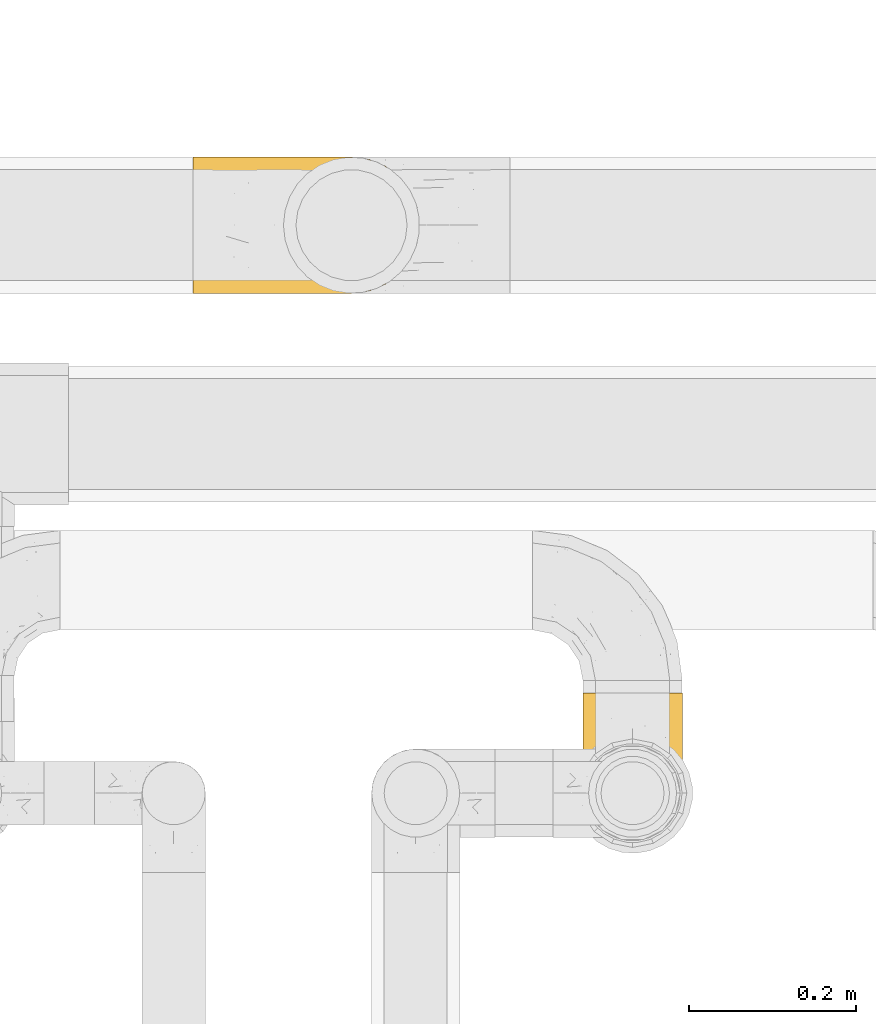
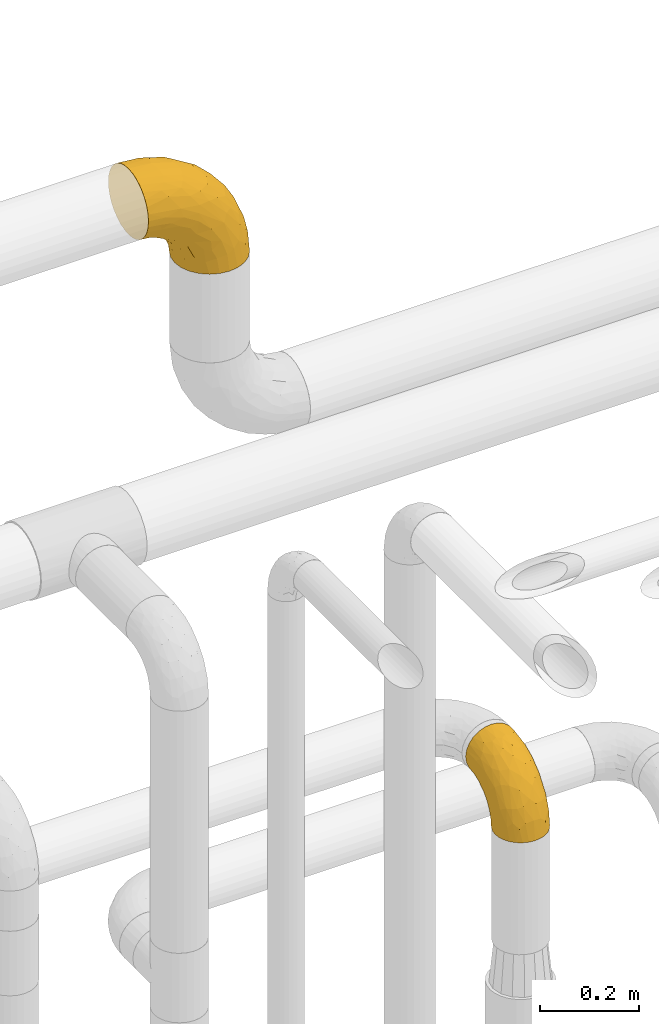
# One storey, part 475 of 827: 2 coverings.
"""IFC2X3 building model written with IfcOpenShell, lengths in millimetres."""

from ifc_helpers import new_model, entity, si_unit, converted_unit, derived_unit, direction, frame, origin, place, context, subcontext, project, spatial, faceted_brep, element, save


model = new_model("IFC2X3")

# Units and contexts
model_context = context("Model", 3, precision=0.01, world=origin(), true_north=direction((6.12303176911189e-17, 1.0)))
body_context = subcontext(model_context, "Body", "Model", "MODEL_VIEW")
ifc_project = project(units=[si_unit("LENGTHUNIT", "METRE", prefix="MILLI"), si_unit("AREAUNIT", "SQUARE_METRE"), si_unit("VOLUMEUNIT", "CUBIC_METRE"), converted_unit("PLANEANGLEUNIT", "DEGREE", entity("IfcRatioMeasure", 0.0174532925199433), si_unit("PLANEANGLEUNIT", "RADIAN"), dimensions=[0, 0, 0, 0, 0, 0, 0]), si_unit("MASSUNIT", "GRAM", prefix="KILO"), derived_unit("MASSDENSITYUNIT", [(si_unit("MASSUNIT", "GRAM", prefix="KILO"), 1), (si_unit("LENGTHUNIT", "METRE"), -3)]), derived_unit("MOMENTOFINERTIAUNIT", [(si_unit("LENGTHUNIT", "METRE"), 4)]), si_unit("TIMEUNIT", "SECOND"), si_unit("FREQUENCYUNIT", "HERTZ"), si_unit("THERMODYNAMICTEMPERATUREUNIT", "DEGREE_CELSIUS"), derived_unit("THERMALTRANSMITTANCEUNIT", [(si_unit("MASSUNIT", "GRAM", prefix="KILO"), 1), (si_unit("THERMODYNAMICTEMPERATUREUNIT", "KELVIN"), -1), (si_unit("TIMEUNIT", "SECOND"), -3)]), derived_unit("VOLUMETRICFLOWRATEUNIT", [(si_unit("LENGTHUNIT", "METRE"), 3), (si_unit("TIMEUNIT", "SECOND"), -1)]), derived_unit("MASSFLOWRATEUNIT", [(si_unit("MASSUNIT", "GRAM", prefix="KILO"), 1), (si_unit("TIMEUNIT", "SECOND"), -1)]), derived_unit("ROTATIONALFREQUENCYUNIT", [(si_unit("TIMEUNIT", "SECOND"), -1)]), si_unit("ELECTRICCURRENTUNIT", "AMPERE"), si_unit("ELECTRICVOLTAGEUNIT", "VOLT"), si_unit("POWERUNIT", "WATT"), si_unit("FORCEUNIT", "NEWTON", prefix="KILO"), si_unit("ILLUMINANCEUNIT", "LUX"), si_unit("LUMINOUSFLUXUNIT", "LUMEN"), si_unit("LUMINOUSINTENSITYUNIT", "CANDELA"), derived_unit("USERDEFINED", [(si_unit("MASSUNIT", "GRAM", prefix="KILO"), -1), (si_unit("LENGTHUNIT", "METRE"), -2), (si_unit("TIMEUNIT", "SECOND"), 3), (si_unit("LUMINOUSFLUXUNIT", "LUMEN"), 1)]), derived_unit("LINEARVELOCITYUNIT", [(si_unit("LENGTHUNIT", "METRE"), 1), (si_unit("TIMEUNIT", "SECOND"), -1)]), si_unit("PRESSUREUNIT", "PASCAL"), derived_unit("USERDEFINED", [(si_unit("LENGTHUNIT", "METRE"), -2), (si_unit("MASSUNIT", "GRAM", prefix="KILO"), 1), (si_unit("TIMEUNIT", "SECOND"), -2)]), derived_unit("LINEARFORCEUNIT", [(si_unit("MASSUNIT", "GRAM", prefix="KILO"), 1), (si_unit("LENGTHUNIT", "METRE"), 1), (si_unit("TIMEUNIT", "SECOND"), -2), (si_unit("LENGTHUNIT", "METRE"), -1)]), derived_unit("PLANARFORCEUNIT", [(si_unit("MASSUNIT", "GRAM", prefix="KILO"), 1), (si_unit("LENGTHUNIT", "METRE"), 1), (si_unit("TIMEUNIT", "SECOND"), -2), (si_unit("LENGTHUNIT", "METRE"), -2)])], contexts=[model_context])

# Site, building, storey
site_placement = place(None, origin())
site = spatial("IfcSite", under=ifc_project, at=site_placement, CompositionType="ELEMENT")
building_placement = place(site_placement, origin())
building = spatial("IfcBuilding", under=site, at=building_placement, CompositionType="ELEMENT")
storey_placement = place(building_placement, frame((0.0, 0.0, 28200.0)))
storey = spatial("IfcBuildingStorey", under=building, at=storey_placement, Name="08", CompositionType="ELEMENT", Elevation=28200.0)

# Coverings
covering_1_placement = place(storey_placement, frame((57719.45, 18097.0, 3308.15)))
element("IfcCovering", 1, at=covering_1_placement, inside=storey, Name=":ADSK_", ObjectType=":ADSK_", PredefinedType="INSULATION", context=body_context, shape_type="Brep", body=[
    faceted_brep([(1.6, 7.8, 222.78), (1.6, 15.33, 236.87), (1.6, 25.47, 249.22), (1.6, 37.82, 259.36), (1.6, 51.91, 266.89), (1.6, 67.2, 271.53), (1.6, 83.1, 273.1), (1.6, 99.0, 271.53), (1.6, 114.28, 266.89), (1.6, 128.37, 259.36), (1.6, 140.72, 249.22), (1.6, 150.86, 236.87), (1.6, 158.39, 222.78), (1.6, 163.03, 207.49), (1.6, 164.6, 191.6), (1.6, 163.03, 175.7), (1.6, 158.39, 160.41), (1.6, 150.86, 146.32), (1.6, 140.72, 133.97), (1.6, 128.37, 123.83), (1.6, 114.28, 116.3), (1.6, 98.99, 111.66), (1.6, 83.1, 110.1), (1.6, 67.2, 111.66), (1.6, 51.91, 116.3), (1.6, 37.82, 123.83), (1.6, 25.47, 133.97), (1.6, 15.33, 146.32), (1.6, 7.8, 160.41), (1.6, 3.16, 175.7), (1.6, 1.6, 191.6), (1.6, 3.16, 207.5), (112.87, 104.19, 1.6), (121.01, 123.85, 1.6), (133.97, 140.72, 1.6), (150.85, 153.68, 1.6), (170.5, 161.82, 1.6), (191.6, 164.6, 1.6), (212.69, 161.82, 1.6), (232.35, 153.68, 1.6), (249.22, 140.72, 1.6), (262.18, 123.85, 1.6), (270.32, 104.19, 1.6), (273.1, 83.1, 1.6), (270.32, 62.0, 1.6), (262.18, 42.35, 1.6), (249.22, 25.47, 1.6), (232.35, 12.51, 1.6), (212.69, 4.37, 1.6), (191.6, 1.6, 1.6), (170.5, 4.37, 1.6), (150.85, 12.51, 1.6), (133.97, 25.47, 1.6), (121.01, 42.35, 1.6), (112.87, 62.0, 1.6), (110.1, 83.1, 1.6), (259.24, 61.52, 77.51), (267.88, 83.1, 54.56), (252.43, 83.1, 105.49), (232.27, 33.48, 109.47), (203.25, 37.62, 161.95), (208.72, 25.88, 138.06), (161.26, 39.19, 205.1), (208.94, 54.26, 168.59), (171.1, 58.86, 208.94), (210.75, 69.72, 172.96), (56.09, 13.06, 226.77), (234.92, 46.89, 122.99), (237.78, 64.87, 131.27), (135.85, 23.27, 206.95), (90.98, 23.58, 230.44), (106.5, 14.32, 210.46), (203.21, 3.63, 53.16), (172.78, 1.6, 84.03), (186.83, 1.6, 43.87), (227.34, 83.1, 152.43), (107.06, 48.22, 243.25), (61.85, 46.55, 257.44), (100.97, 35.04, 237.33), (193.57, 83.1, 193.57), (152.43, 83.1, 227.34), (218.24, 9.67, 63.71), (227.74, 21.98, 92.99), (239.64, 19.94, 42.41), (250.37, 35.76, 63.41), (43.87, 1.6, 186.83), (78.77, 3.68, 195.08), (181.88, 6.22, 122.49), (192.35, 14.93, 138.28), (151.91, 14.98, 181.92), (261.16, 48.51, 48.64), (125.68, 7.94, 185.11), (120.31, 3.15, 169.75), (62.42, 60.95, 263.05), (114.22, 65.41, 246.5), (43.77, 21.67, 241.49), (175.87, 24.32, 175.87), (55.94, 33.42, 250.34), (105.49, 83.1, 252.43), (54.56, 83.1, 267.88), (84.03, 1.6, 172.78), (120.06, 1.6, 150.14), (150.14, 1.6, 120.06), (143.53, 14.96, 32.61), (124.28, 28.5, 43.04), (164.08, 4.85, 41.06), (63.41, 24.93, 119.26), (34.09, 27.47, 127.92), (50.98, 39.14, 112.47), (71.3, 56.48, 90.5), (35.12, 83.1, 104.78), (65.37, 83.1, 89.37), (103.16, 45.76, 60.79), (108.14, 27.44, 76.89), (82.77, 36.99, 93.74), (101.65, 4.28, 138.12), (76.68, 4.76, 151.34), (87.17, 10.22, 129.05), (149.53, 3.62, 89.24), (116.92, 6.16, 116.92), (116.45, 14.37, 92.03), (114.12, 49.05, 29.57), (32.67, 56.71, 110.12), (26.08, 17.27, 141.41), (54.1, 14.26, 138.22), (137.51, 11.34, 68.2), (108.77, 67.27, 26.59), (99.57, 65.22, 52.67), (89.37, 83.1, 65.37), (104.78, 83.1, 35.12), (90.24, 20.69, 106.81), (36.38, 8.03, 155.99), (57.28, 3.22, 166.25), (28.92, 3.48, 171.98), (83.96, 67.43, 74.54), (153.13, 6.04, 62.85), (24.92, 42.07, 118.88), (103.17, 12.13, 111.86), (137.51, 154.85, 68.2), (124.28, 137.69, 43.04), (108.14, 138.75, 76.89), (116.45, 151.82, 92.03), (108.77, 98.92, 26.59), (99.57, 100.98, 52.67), (50.98, 127.05, 112.47), (63.41, 141.26, 119.26), (82.77, 129.2, 93.74), (28.92, 162.71, 171.98), (71.3, 109.71, 90.5), (143.53, 151.23, 32.61), (164.08, 161.34, 41.06), (24.92, 124.12, 118.88), (34.09, 138.72, 127.91), (103.16, 120.43, 60.79), (83.96, 98.76, 74.54), (57.28, 162.97, 166.25), (36.38, 158.16, 155.99), (186.83, 164.6, 43.87), (114.12, 117.14, 29.57), (26.08, 148.92, 141.41), (32.67, 109.48, 110.12), (162.83, 163.11, 68.35), (149.53, 162.57, 89.24), (84.03, 164.6, 172.78), (120.06, 164.6, 150.14), (76.68, 161.43, 151.34), (150.14, 164.6, 120.06), (172.78, 164.6, 84.03), (90.24, 145.5, 106.81), (116.92, 160.03, 116.92), (54.1, 151.93, 138.22), (87.17, 155.97, 129.05), (101.65, 161.91, 138.12), (43.87, 164.6, 186.83), (102.74, 153.84, 111.73), (250.37, 130.43, 63.41), (90.98, 142.61, 230.44), (100.94, 131.16, 237.34), (141.5, 132.16, 214.88), (45.45, 119.84, 260.65), (195.08, 162.51, 78.77), (169.75, 163.04, 120.31), (185.11, 158.25, 125.68), (175.87, 141.87, 175.87), (190.61, 124.71, 180.24), (122.49, 159.97, 181.88), (75.94, 163.28, 192.21), (212.14, 108.71, 166.39), (215.84, 155.76, 76.36), (234.04, 133.19, 104.7), (227.74, 144.21, 92.99), (210.82, 138.09, 138.7), (252.63, 118.28, 81.73), (43.77, 144.52, 241.49), (171.1, 107.33, 208.94), (67.05, 152.26, 225.32), (234.92, 119.3, 122.99), (240.01, 103.26, 126.09), (239.64, 146.25, 42.41), (259.24, 104.67, 77.51), (124.28, 151.11, 201.91), (63.96, 159.51, 210.82), (114.23, 100.78, 246.49), (195.27, 149.54, 138.52), (159.59, 154.66, 167.35), (62.43, 105.24, 263.05), (55.94, 132.77, 250.34), (107.06, 117.97, 243.25)], [[[0, 1, 2, 3, 4, 5, 6, 7, 8, 9, 10, 11, 12, 13, 14, 15, 16, 17, 18, 19, 20, 21, 22, 23, 24, 25, 26, 27, 28, 29, 30, 31]], [[32, 33, 34, 35, 36, 37, 38, 39, 40, 41, 42, 43, 44, 45, 46, 47, 48, 49, 50, 51, 52, 53, 54, 55]], [[56, 57, 58]], [[57, 44, 43]], [[59, 60, 61]], [[62, 63, 64]], [[63, 65, 64]], [[1, 0, 66]], [[67, 68, 63]], [[69, 70, 71]], [[72, 73, 74]], [[75, 68, 58]], [[76, 77, 78]], [[64, 79, 80]], [[81, 48, 47]], [[82, 83, 84]], [[31, 85, 86]], [[71, 70, 66]], [[47, 83, 81]], [[87, 88, 89]], [[69, 62, 78]], [[49, 48, 72]], [[90, 44, 56]], [[48, 81, 72]], [[87, 91, 92]], [[93, 76, 94]], [[70, 95, 66]], [[88, 96, 89]], [[45, 84, 46]], [[2, 95, 97]], [[4, 93, 5]], [[98, 99, 93]], [[59, 84, 67]], [[3, 97, 77]], [[71, 86, 91]], [[4, 3, 77]], [[90, 84, 45]], [[99, 6, 5]], [[83, 47, 46]], [[95, 2, 1]], [[94, 80, 98]], [[100, 101, 92]], [[66, 31, 86]], [[60, 63, 62]], [[85, 31, 30]], [[102, 87, 92]], [[93, 77, 76]], [[91, 86, 92]], [[44, 57, 56]], [[86, 85, 100]], [[78, 97, 70]], [[87, 102, 73]], [[2, 97, 3]], [[67, 84, 90]], [[31, 66, 0]], [[93, 94, 98]], [[88, 81, 82]], [[99, 5, 93]], [[87, 73, 72]], [[66, 95, 1]], [[97, 95, 70]], [[86, 71, 66]], [[69, 89, 96]], [[89, 71, 91]], [[69, 96, 62]], [[60, 62, 96]], [[76, 62, 64]], [[71, 89, 69]], [[87, 89, 91]], [[81, 88, 87]], [[61, 88, 82]], [[61, 60, 96]], [[60, 67, 63]], [[68, 67, 56]], [[79, 65, 75]], [[58, 68, 56]], [[65, 68, 75]], [[64, 65, 79]], [[68, 65, 63]], [[76, 64, 94]], [[80, 94, 64]], [[100, 92, 86]], [[92, 101, 102]], [[88, 61, 96]], [[59, 61, 82]], [[84, 59, 82]], [[60, 59, 67]], [[87, 72, 81]], [[49, 72, 74]], [[84, 83, 46]], [[81, 83, 82]], [[69, 78, 70]], [[62, 76, 78]], [[4, 77, 93]], [[78, 77, 97]], [[44, 90, 45]], [[67, 90, 56]], [[103, 104, 52]], [[50, 49, 74]], [[50, 74, 105]], [[106, 107, 108]], [[109, 110, 111]], [[112, 113, 114]], [[104, 113, 112]], [[73, 105, 74]], [[115, 116, 117]], [[118, 119, 120]], [[104, 53, 52]], [[51, 103, 52]], [[53, 121, 54]], [[24, 23, 122]], [[123, 107, 124]], [[122, 109, 108]], [[125, 120, 113]], [[55, 54, 126]], [[102, 118, 73]], [[127, 126, 121]], [[128, 129, 127]], [[105, 51, 50]], [[102, 101, 119]], [[120, 130, 113]], [[26, 123, 27]], [[27, 131, 28]], [[132, 85, 133]], [[85, 29, 133]], [[134, 111, 128]], [[28, 133, 29]], [[30, 29, 85]], [[116, 131, 124]], [[135, 73, 118]], [[27, 123, 131]], [[110, 23, 22]], [[136, 122, 108]], [[24, 136, 25]], [[114, 108, 109]], [[119, 115, 117]], [[136, 107, 25]], [[128, 127, 134]], [[122, 110, 109]], [[104, 112, 121]], [[107, 106, 124]], [[107, 26, 25]], [[23, 110, 122]], [[101, 100, 116]], [[131, 132, 133]], [[105, 135, 103]], [[116, 124, 117]], [[122, 136, 24]], [[107, 136, 108]], [[28, 131, 133]], [[131, 116, 132]], [[126, 127, 129]], [[134, 112, 109]], [[107, 123, 26]], [[131, 123, 124]], [[104, 121, 53]], [[127, 121, 112]], [[105, 103, 51]], [[104, 103, 125]], [[116, 100, 132]], [[85, 132, 100]], [[106, 117, 124]], [[137, 130, 120]], [[114, 106, 108]], [[106, 130, 117]], [[119, 118, 102]], [[135, 118, 125]], [[125, 113, 104]], [[114, 113, 130]], [[114, 130, 106]], [[112, 114, 109]], [[118, 120, 125]], [[117, 137, 119]], [[55, 126, 129]], [[121, 126, 54]], [[112, 134, 127]], [[111, 134, 109]], [[119, 101, 115]], [[101, 116, 115]], [[103, 135, 125]], [[73, 135, 105]], [[130, 137, 117]], [[120, 119, 137]], [[138, 139, 140]], [[140, 141, 138]], [[55, 129, 142]], [[143, 142, 129]], [[144, 145, 146]], [[147, 16, 15]], [[110, 148, 111]], [[128, 143, 129]], [[149, 150, 35]], [[151, 152, 144]], [[153, 143, 154]], [[147, 155, 156]], [[35, 150, 36]], [[37, 36, 157]], [[35, 34, 149]], [[139, 33, 158]], [[159, 152, 18]], [[150, 157, 36]], [[140, 139, 153]], [[139, 34, 33]], [[110, 21, 160]], [[150, 161, 157]], [[20, 19, 151]], [[161, 138, 162]], [[110, 22, 21]], [[163, 164, 165]], [[166, 167, 162]], [[151, 160, 20]], [[140, 146, 168]], [[111, 148, 154]], [[164, 166, 169]], [[18, 152, 19]], [[170, 156, 165]], [[17, 159, 18]], [[158, 33, 32]], [[171, 165, 172]], [[155, 165, 156]], [[148, 110, 160]], [[170, 159, 156]], [[160, 144, 148]], [[15, 14, 173]], [[170, 171, 145]], [[149, 139, 138]], [[15, 173, 147]], [[144, 152, 145]], [[156, 17, 16]], [[165, 171, 170]], [[20, 160, 21]], [[171, 172, 169]], [[169, 166, 162]], [[152, 151, 19]], [[160, 151, 144]], [[155, 173, 163]], [[156, 16, 147]], [[154, 143, 128]], [[143, 153, 158]], [[156, 159, 17]], [[152, 159, 170]], [[158, 32, 142]], [[139, 158, 153]], [[139, 149, 34]], [[150, 149, 138]], [[173, 155, 147]], [[163, 165, 155]], [[174, 169, 141]], [[145, 171, 168]], [[170, 145, 152]], [[146, 145, 168]], [[161, 162, 167]], [[162, 138, 141]], [[146, 153, 148]], [[140, 168, 141]], [[153, 146, 140]], [[144, 146, 148]], [[174, 141, 168]], [[162, 141, 169]], [[158, 142, 143]], [[55, 142, 32]], [[111, 154, 128]], [[153, 154, 148]], [[165, 164, 172]], [[164, 169, 172]], [[157, 161, 167]], [[138, 161, 150]], [[168, 171, 174]], [[169, 174, 171]], [[41, 40, 175]], [[176, 177, 178]], [[9, 8, 179]], [[180, 181, 182]], [[157, 180, 37]], [[183, 178, 184]], [[164, 185, 181]], [[13, 186, 173]], [[187, 79, 75]], [[167, 166, 181]], [[186, 163, 173]], [[182, 188, 180]], [[57, 43, 42]], [[189, 190, 191]], [[164, 186, 185]], [[192, 41, 175]], [[193, 11, 10]], [[178, 194, 184]], [[12, 11, 195]], [[196, 187, 197]], [[40, 198, 175]], [[198, 40, 39]], [[58, 199, 197]], [[200, 185, 201]], [[163, 186, 164]], [[201, 185, 186]], [[202, 80, 194]], [[190, 203, 191]], [[201, 186, 13]], [[204, 185, 200]], [[201, 13, 12]], [[41, 199, 42]], [[195, 200, 201]], [[98, 205, 99]], [[57, 42, 199]], [[13, 173, 14]], [[58, 57, 199]], [[193, 206, 176]], [[80, 79, 194]], [[207, 205, 202]], [[196, 184, 187]], [[202, 205, 98]], [[205, 179, 8]], [[9, 206, 10]], [[207, 206, 179]], [[182, 203, 188]], [[6, 99, 7]], [[188, 38, 180]], [[203, 182, 204]], [[7, 205, 8]], [[37, 180, 38]], [[167, 180, 157]], [[7, 99, 205]], [[182, 181, 185]], [[11, 193, 195]], [[196, 191, 184]], [[175, 189, 192]], [[198, 188, 190]], [[38, 188, 39]], [[206, 193, 10]], [[195, 193, 176]], [[195, 176, 200]], [[12, 195, 201]], [[178, 200, 176]], [[185, 204, 182]], [[200, 183, 204]], [[203, 204, 183]], [[191, 203, 183]], [[188, 203, 190]], [[184, 191, 183]], [[190, 189, 175]], [[200, 178, 183]], [[184, 194, 187]], [[177, 176, 206]], [[194, 178, 207]], [[79, 187, 194]], [[197, 199, 192]], [[187, 75, 197]], [[58, 197, 75]], [[191, 196, 189]], [[192, 189, 196]], [[80, 202, 98]], [[194, 207, 202]], [[167, 181, 180]], [[181, 166, 164]], [[188, 198, 39]], [[175, 198, 190]], [[207, 179, 205]], [[9, 179, 206]], [[197, 192, 196]], [[41, 192, 199]], [[206, 207, 177]], [[207, 178, 177]]]),
])
covering_2_placement = place(storey_placement, frame((58186.47, 17438.9, 2178.4)))
element("IfcCovering", 2, at=covering_2_placement, inside=storey, Name=":ADSK_", ObjectType=":ADSK_", PredefinedType="INSULATION", context=body_context, shape_type="Brep", body=[
    faceted_brep([(119.1, 47.85, 1.6), (114.7, 35.28, 1.6), (107.61, 23.99, 1.6), (98.19, 14.57, 1.6), (86.9, 7.48, 1.6), (74.32, 3.08, 1.6), (61.1, 1.6, 1.6), (47.85, 3.09, 1.6), (35.28, 7.49, 1.6), (23.99, 14.58, 1.6), (14.57, 24.0, 1.6), (7.48, 35.29, 1.6), (3.08, 47.87, 1.6), (1.6, 61.1, 1.6), (3.09, 74.34, 1.6), (7.49, 86.92, 1.6), (14.58, 98.2, 1.6), (24.0, 107.62, 1.6), (35.29, 114.71, 1.6), (47.87, 119.11, 1.6), (61.1, 120.6, 1.6), (74.34, 119.1, 1.6), (86.92, 114.7, 1.6), (98.2, 107.61, 1.6), (107.62, 98.19, 1.6), (114.71, 86.9, 1.6), (119.11, 74.32, 1.6), (120.6, 61.1, 1.6), (45.7, 181.1, 64.12), (31.35, 181.1, 70.07), (19.02, 181.1, 79.52), (9.57, 181.1, 91.85), (3.62, 181.1, 106.2), (1.6, 181.1, 121.6), (3.62, 181.1, 137.0), (9.57, 181.1, 151.35), (19.02, 181.1, 163.67), (31.35, 181.1, 173.12), (45.7, 181.1, 179.07), (61.1, 181.1, 181.1), (76.5, 181.1, 179.07), (90.85, 181.1, 173.12), (103.17, 181.1, 163.67), (112.62, 181.1, 151.35), (118.57, 181.1, 137.0), (120.6, 181.1, 121.6), (118.57, 181.1, 106.2), (112.62, 181.1, 91.85), (103.17, 181.1, 79.52), (90.85, 181.1, 70.07), (76.5, 181.1, 64.12), (61.1, 181.1, 62.1), (95.88, 149.36, 166.85), (82.3, 137.95, 171.8), (94.1, 112.73, 156.7), (71.89, 142.53, 175.89), (61.1, 134.64, 174.98), (110.03, 30.78, 34.39), (80.11, 74.16, 141.86), (61.1, 91.35, 157.05), (61.1, 54.17, 128.52), (115.76, 109.16, 125.77), (113.03, 132.51, 142.49), (106.83, 100.6, 137.62), (118.0, 143.49, 133.72), (119.56, 118.25, 116.57), (91.22, 53.89, 116.34), (97.67, 84.22, 137.54), (83.16, 106.32, 160.1), (71.84, 113.45, 166.8), (106.27, 137.68, 154.26), (61.1, 7.71, 48.05), (79.29, 9.86, 44.99), (89.43, 25.56, 75.77), (76.37, 40.03, 109.34), (73.84, 20.36, 78.35), (118.7, 85.71, 96.98), (113.14, 75.88, 106.86), (114.84, 51.26, 67.36), (119.09, 56.83, 49.85), (120.6, 84.01, 72.13), (120.6, 110.56, 98.68), (120.6, 127.29, 107.2), (120.6, 144.01, 115.72), (61.1, 25.64, 91.35), (101.09, 22.95, 45.24), (106.71, 40.15, 73.45), (91.36, 12.95, 33.95), (116.15, 42.03, 32.97), (120.6, 63.41, 16.23), (120.6, 66.97, 38.68), (98.77, 31.89, 74.48), (120.6, 97.29, 85.4), (104.27, 67.3, 115.39), (120.6, 75.49, 55.4), (120.6, 166.46, 119.28), (114.26, 141.36, 85.98), (113.3, 121.72, 71.16), (106.08, 138.16, 70.35), (118.29, 159.88, 103.0), (119.17, 128.08, 94.6), (102.39, 126.23, 55.86), (119.07, 110.87, 81.81), (74.66, 162.96, 60.95), (72.06, 146.61, 52.54), (61.1, 157.94, 57.49), (107.18, 102.08, 24.83), (103.18, 112.03, 37.73), (111.64, 107.36, 50.74), (111.23, 162.91, 87.65), (101.44, 157.88, 74.24), (82.78, 118.07, 15.74), (95.99, 111.72, 20.12), (88.46, 151.58, 61.93), (85.34, 167.61, 65.86), (75.22, 132.93, 40.95), (61.1, 138.32, 44.38), (116.35, 90.2, 38.05), (119.46, 87.09, 55.63), (116.78, 98.46, 56.15), (85.13, 122.87, 31.75), (89.52, 132.83, 49.11), (119.0, 76.52, 20.72), (94.63, 117.49, 32.8), (113.92, 90.0, 18.32), (73.67, 123.48, 24.08), (61.1, 125.2, 24.75), (119.4, 97.44, 70.12), (97.35, 139.94, 61.67), (119.56, 79.72, 41.55), (117.72, 145.56, 96.92), (108.82, 152.47, 81.07), (16.12, 138.17, 70.33), (19.81, 126.24, 55.85), (8.9, 121.74, 71.15), (26.21, 111.73, 20.12), (15.02, 102.09, 24.84), (24.86, 139.94, 61.65), (5.84, 90.22, 38.08), (2.63, 79.72, 41.53), (2.73, 87.08, 55.63), (46.99, 132.91, 40.93), (47.54, 162.97, 60.95), (36.85, 167.61, 65.86), (10.96, 162.91, 87.65), (13.37, 152.47, 81.07), (7.93, 141.36, 85.98), (3.02, 128.08, 94.6), (2.89, 112.07, 84.2), (1.6, 110.56, 98.68), (3.9, 159.88, 103.0), (1.6, 166.46, 119.28), (26.96, 121.68, 40.95), (37.08, 122.86, 31.73), (20.75, 157.88, 74.24), (10.56, 107.38, 50.74), (50.11, 146.61, 52.54), (19.02, 112.05, 37.73), (48.54, 123.48, 24.06), (3.81, 101.72, 68.67), (8.27, 90.01, 18.33), (4.47, 145.56, 96.92), (39.43, 118.07, 15.72), (3.19, 76.53, 20.72), (32.68, 132.81, 49.08), (1.6, 66.97, 38.68), (1.6, 63.41, 16.23), (1.6, 75.49, 55.4), (5.87, 97.07, 51.76), (1.6, 97.29, 85.4), (1.6, 144.01, 115.72), (1.6, 127.29, 107.2), (1.6, 84.01, 72.13), (33.73, 151.59, 61.93), (28.09, 112.73, 156.7), (26.31, 149.36, 166.85), (15.92, 137.68, 154.26), (9.16, 132.51, 142.49), (50.3, 142.53, 175.89), (39.89, 137.95, 171.8), (50.35, 113.45, 166.8), (2.63, 118.25, 116.57), (15.36, 100.6, 137.62), (45.82, 40.03, 109.34), (30.97, 53.89, 116.34), (32.75, 25.56, 75.76), (3.49, 85.71, 96.98), (4.19, 143.49, 133.72), (39.03, 106.32, 160.1), (44.85, 21.51, 78.71), (42.89, 9.86, 44.98), (42.08, 74.16, 141.86), (6.03, 42.04, 32.97), (3.1, 56.84, 49.86), (6.43, 109.16, 125.77), (9.05, 75.88, 106.86), (12.15, 30.8, 34.39), (21.09, 22.96, 45.23), (24.52, 84.22, 137.54), (30.82, 12.96, 33.95), (7.35, 51.28, 67.37), (15.47, 40.16, 73.45), (17.92, 67.3, 115.39), (23.41, 31.9, 74.47)], [[[0, 1, 2, 3, 4, 5, 6, 7, 8, 9, 10, 11, 12, 13, 14, 15, 16, 17, 18, 19, 20, 21, 22, 23, 24, 25, 26, 27]], [[28, 29, 30, 31, 32, 33, 34, 35, 36, 37, 38, 39, 40, 41, 42, 43, 44, 45, 46, 47, 48, 49, 50, 51]], [[52, 53, 54]], [[55, 39, 56]], [[57, 2, 1]], [[58, 59, 60]], [[61, 62, 63]], [[64, 61, 65]], [[58, 66, 67]], [[53, 68, 54]], [[41, 40, 53]], [[53, 69, 68]], [[70, 42, 52]], [[42, 41, 52]], [[71, 5, 72]], [[73, 74, 75]], [[43, 70, 62]], [[45, 44, 64]], [[76, 77, 78]], [[79, 80, 76]], [[65, 81, 82, 83]], [[74, 60, 84]], [[85, 2, 57]], [[85, 57, 86]], [[2, 85, 3]], [[42, 70, 43]], [[5, 4, 72]], [[72, 87, 73]], [[4, 3, 87]], [[5, 71, 6]], [[75, 74, 84]], [[64, 62, 61]], [[79, 78, 88]], [[54, 67, 63]], [[74, 58, 60]], [[65, 76, 81]], [[79, 27, 89, 90]], [[75, 71, 72]], [[85, 86, 91]], [[78, 57, 88]], [[56, 69, 55]], [[76, 78, 79]], [[76, 80, 92, 81]], [[77, 76, 61]], [[69, 56, 59]], [[4, 87, 72]], [[91, 66, 73]], [[58, 74, 66]], [[3, 85, 87]], [[73, 87, 85]], [[88, 57, 1]], [[86, 57, 78]], [[77, 86, 78]], [[93, 66, 91]], [[73, 66, 74]], [[67, 93, 63]], [[1, 0, 88]], [[0, 27, 79]], [[0, 79, 88]], [[79, 90, 94, 80]], [[64, 83, 95, 45]], [[76, 65, 61]], [[83, 64, 65]], [[62, 44, 43]], [[62, 64, 44]], [[63, 62, 70]], [[54, 63, 70]], [[63, 93, 77]], [[63, 77, 61]], [[77, 93, 86]], [[67, 54, 68]], [[66, 93, 67]], [[53, 52, 41]], [[70, 52, 54]], [[58, 69, 59]], [[55, 69, 53]], [[69, 58, 68]], [[67, 68, 58]], [[53, 40, 55]], [[39, 55, 40]], [[71, 75, 84]], [[73, 75, 72]], [[91, 86, 93]], [[73, 85, 91]], [[96, 97, 98]], [[83, 99, 95]], [[82, 81, 100]], [[95, 99, 46]], [[101, 98, 97]], [[47, 46, 99]], [[97, 100, 102]], [[103, 104, 105]], [[106, 107, 108]], [[109, 48, 47]], [[48, 110, 49]], [[108, 101, 97]], [[111, 112, 22]], [[51, 50, 103]], [[113, 103, 114]], [[23, 22, 112]], [[115, 116, 104]], [[108, 117, 106]], [[112, 106, 23]], [[94, 118, 80]], [[108, 119, 117]], [[120, 115, 121]], [[112, 107, 106]], [[25, 122, 26]], [[122, 89, 26]], [[101, 123, 121]], [[109, 110, 48]], [[124, 25, 24]], [[125, 20, 126]], [[120, 111, 125]], [[110, 113, 114]], [[127, 97, 102]], [[106, 24, 23]], [[125, 115, 120]], [[111, 22, 21]], [[126, 115, 125]], [[117, 124, 106]], [[110, 98, 128]], [[117, 129, 124]], [[117, 118, 129]], [[100, 97, 96]], [[124, 122, 25]], [[83, 82, 130]], [[99, 130, 109]], [[100, 81, 102]], [[100, 130, 82]], [[130, 100, 96]], [[81, 92, 102]], [[127, 80, 118]], [[21, 20, 125]], [[111, 120, 123]], [[21, 125, 111]], [[115, 126, 116]], [[104, 116, 105]], [[101, 107, 123]], [[104, 121, 115]], [[128, 121, 113]], [[105, 51, 103]], [[121, 104, 113]], [[114, 103, 50]], [[113, 104, 103]], [[106, 124, 24]], [[94, 129, 118]], [[123, 107, 112]], [[101, 108, 107]], [[99, 109, 47]], [[131, 109, 96]], [[89, 122, 90]], [[89, 27, 26]], [[122, 129, 90]], [[97, 127, 119]], [[119, 127, 118]], [[102, 92, 127]], [[90, 129, 94]], [[80, 127, 92]], [[124, 129, 122]], [[117, 119, 118]], [[97, 119, 108]], [[50, 49, 114]], [[110, 114, 49]], [[109, 130, 96]], [[130, 99, 83]], [[128, 98, 101]], [[98, 110, 131]], [[121, 128, 101]], [[110, 128, 113]], [[46, 45, 95]], [[111, 123, 112]], [[121, 123, 120]], [[98, 131, 96]], [[110, 109, 131]], [[132, 133, 134]], [[135, 17, 136]], [[132, 137, 133]], [[138, 139, 140]], [[126, 141, 116]], [[105, 142, 51]], [[16, 136, 17]], [[142, 143, 28]], [[144, 145, 146]], [[147, 148, 149]], [[31, 150, 32]], [[150, 151, 32]], [[135, 152, 153]], [[30, 29, 154]], [[155, 136, 138]], [[31, 30, 144]], [[156, 116, 141]], [[136, 155, 157]], [[126, 158, 141]], [[159, 148, 134]], [[20, 19, 158]], [[156, 142, 105]], [[160, 136, 16]], [[147, 161, 146]], [[135, 18, 17]], [[18, 162, 19]], [[136, 157, 135]], [[146, 145, 132]], [[160, 163, 139]], [[16, 15, 160]], [[15, 14, 163]], [[164, 141, 153]], [[133, 155, 134]], [[152, 135, 157]], [[165, 163, 166]], [[163, 14, 166]], [[162, 135, 153]], [[29, 143, 154]], [[165, 167, 139]], [[162, 158, 19]], [[159, 134, 155]], [[167, 140, 139]], [[140, 168, 138]], [[159, 169, 148]], [[144, 150, 31]], [[161, 170, 150]], [[171, 170, 161]], [[149, 171, 147]], [[134, 147, 146]], [[134, 148, 147]], [[135, 162, 18]], [[169, 159, 172]], [[169, 149, 148]], [[158, 162, 153]], [[158, 153, 141]], [[158, 126, 20]], [[153, 152, 164]], [[116, 156, 105]], [[137, 164, 133]], [[156, 164, 173]], [[164, 156, 141]], [[142, 28, 51]], [[156, 173, 142]], [[143, 142, 173]], [[163, 160, 15]], [[136, 160, 138]], [[155, 133, 157]], [[133, 164, 152]], [[154, 144, 30]], [[144, 146, 161]], [[14, 13, 166]], [[172, 159, 140]], [[140, 167, 172]], [[168, 159, 155]], [[160, 139, 138]], [[165, 139, 163]], [[154, 143, 173]], [[29, 28, 143]], [[171, 161, 147]], [[144, 161, 150]], [[159, 168, 140]], [[155, 138, 168]], [[146, 132, 134]], [[137, 154, 173]], [[154, 137, 132]], [[164, 137, 173]], [[151, 150, 170]], [[151, 33, 32]], [[133, 152, 157]], [[144, 154, 145]], [[132, 145, 154]], [[174, 175, 176]], [[35, 34, 177]], [[178, 179, 180]], [[181, 170, 171, 149]], [[176, 182, 174]], [[183, 184, 185]], [[186, 149, 169, 172]], [[187, 33, 151, 170]], [[179, 188, 180]], [[34, 187, 177]], [[39, 38, 178]], [[189, 185, 190]], [[184, 183, 191]], [[175, 179, 37]], [[38, 37, 179]], [[35, 176, 36]], [[180, 59, 56]], [[192, 193, 12]], [[37, 36, 175]], [[181, 187, 170]], [[181, 186, 194]], [[176, 177, 182]], [[8, 7, 190]], [[194, 186, 195]], [[13, 12, 193]], [[196, 192, 11]], [[10, 9, 197]], [[60, 183, 84]], [[174, 182, 198]], [[197, 196, 10]], [[193, 172, 167, 165]], [[8, 199, 9]], [[189, 183, 185]], [[60, 59, 191]], [[200, 196, 201]], [[190, 199, 8]], [[7, 6, 71]], [[10, 196, 11]], [[202, 203, 184]], [[199, 185, 197]], [[7, 71, 190]], [[183, 60, 191]], [[189, 71, 84]], [[193, 186, 172]], [[200, 201, 195]], [[180, 191, 59]], [[185, 199, 190]], [[197, 9, 199]], [[201, 196, 197]], [[192, 196, 200]], [[203, 201, 197]], [[195, 201, 202]], [[191, 188, 198]], [[202, 201, 203]], [[193, 192, 200]], [[12, 11, 192]], [[186, 193, 200]], [[193, 165, 166, 13]], [[186, 181, 149]], [[187, 181, 194]], [[187, 194, 177]], [[187, 34, 33]], [[194, 195, 182]], [[35, 177, 176]], [[194, 182, 177]], [[182, 202, 198]], [[200, 195, 186]], [[182, 195, 202]], [[202, 184, 198]], [[191, 198, 184]], [[176, 175, 36]], [[179, 175, 174]], [[178, 180, 56]], [[179, 174, 188]], [[198, 188, 174]], [[191, 180, 188]], [[39, 178, 56]], [[38, 179, 178]], [[71, 189, 190]], [[84, 183, 189]], [[197, 185, 203]], [[184, 203, 185]]]),
])

save(model, "model.ifc")
